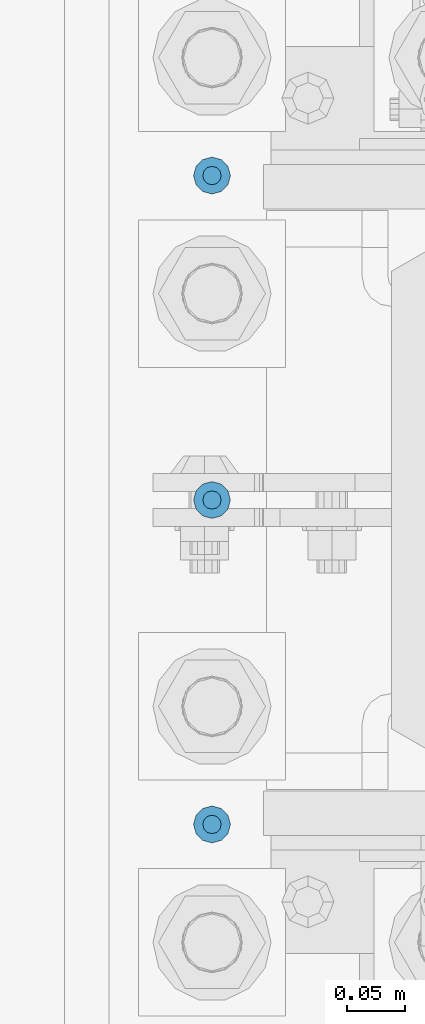
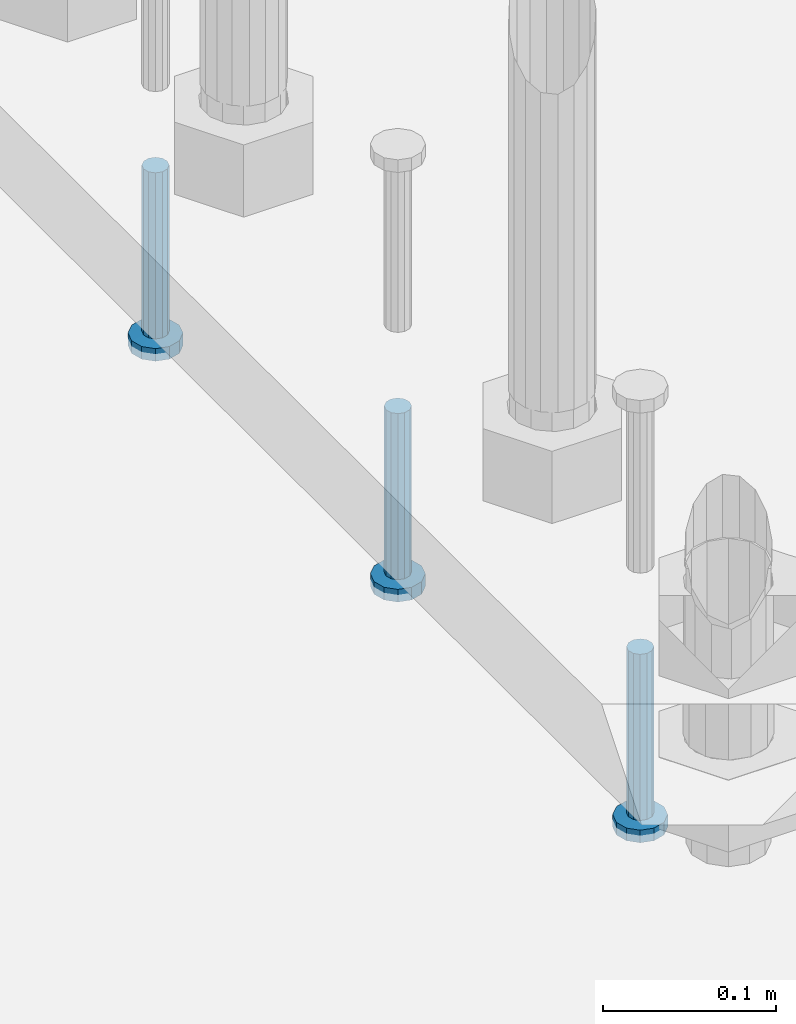
# One storey, part 1243 of 1876: 3 beams, 1 element without a shape of its own.
"""IFC2X3 building model written with IfcOpenShell, lengths in millimetres."""

from ifc_helpers import new_model, si_unit, frame, origin_with_axes, place, context, subcontext, project, spatial, faceted_brep, material, type_object, element, aggregate, save


model = new_model("IFC2X3")

# Units and contexts
model_context = context("Model", 3, precision=1e-05, world=origin_with_axes())
body_context = subcontext(model_context, "Body", "Model", "MODEL_VIEW")
ifc_project = project(units=[si_unit("LENGTHUNIT", "METRE", prefix="MILLI"), si_unit("AREAUNIT", "SQUARE_METRE"), si_unit("VOLUMEUNIT", "CUBIC_METRE"), si_unit("MASSUNIT", "GRAM", prefix="KILO"), si_unit("TIMEUNIT", "SECOND"), si_unit("PLANEANGLEUNIT", "RADIAN"), si_unit("SOLIDANGLEUNIT", "STERADIAN"), si_unit("THERMODYNAMICTEMPERATUREUNIT", "DEGREE_CELSIUS"), si_unit("LUMINOUSINTENSITYUNIT", "LUMEN")], contexts=[model_context])

# Site, building, storey
site_placement = place(None, origin_with_axes())
site = spatial("IfcSite", under=ifc_project, at=site_placement, CompositionType="ELEMENT")
building_placement = place(site_placement, origin_with_axes())
building = spatial("IfcBuilding", under=site, at=building_placement, Name="Undefined", CompositionType="ELEMENT")
storey_placement = place(building_placement, origin_with_axes())
storey = spatial("IfcBuildingStorey", under=building, at=storey_placement, Name="Undefined", CompositionType="ELEMENT", Elevation=0.0)

# Assembly, beams
assembly_placement = place(storey_placement, origin_with_axes())
assembly = element("IfcElementAssembly", 1, at=assembly_placement, inside=storey, Name="TEMPLATE", AssemblyPlace="NOTDEFINED", PredefinedType="RIGID_FRAME")
ifc_material = material(Name="STEEL/A108")
beam_type = type_object("IfcBeamType", Name="5/8-DIA_HEADED ANCHOR STUD", PredefinedType="NOTDEFINED")
beam_1_placement = place(assembly_placement, frame((7416.8, 1803.4, -793.75), z_axis=(1.0, 0.0, 0.0), x_axis=(0.0, 0.0, -1.0)))
beam_1 = element("IfcBeam", 2, at=beam_1_placement, type_object=beam_type, material=ifc_material, Name="HEADED ANCHOR STUD", ObjectType="5/8-DIA_HEADED ANCHOR STUD", context=body_context, shape_type="Brep", body=[
    faceted_brep([(0.0, -7.94000005722046, 0.0), (0.0, -6.86999988555908, -3.97000002861023), (116.84, -6.86999988555908, -3.97000002861023), (116.84, -7.94000005722046, 0.0), (0.0, -3.97000002861023, -6.86999988555908), (116.84, -3.97000002861023, -6.86999988555908), (0.0, 0.0, -7.94000005722046), (116.84, 0.0, -7.94000005722046), (0.0, 3.97000002861023, -6.86999988555908), (116.84, 3.97000002861023, -6.86999988555908), (0.0, 6.86999988555908, -3.97000002861023), (116.84, 6.86999988555908, -3.97000002861023), (0.0, 7.94000005722046, 0.0), (116.84, 7.94000005722046, 0.0), (0.0, 6.86999988555908, 3.97000002861023), (116.84, 6.86999988555908, 3.97000002861023), (0.0, 3.97000002861023, 6.86999988555908), (116.84, 3.97000002861023, 6.86999988555908), (0.0, 0.0, 7.94000005722046), (116.84, 0.0, 7.94000005722046), (0.0, -3.97000002861023, 6.86999988555908), (116.84, -3.97000002861023, 6.86999988555908), (0.0, -6.86999988555908, 3.97000002861023), (116.84, -6.86999988555908, 3.97000002861023), (118.11, -13.75, -7.94000005722046), (118.11, -15.8800001144409, 0.0), (118.11, -7.94000005722046, -13.75), (118.11, 0.0, -15.8800001144409), (118.11, 7.94000005722046, -13.75), (118.11, 13.75, -7.94000005722046), (118.11, 15.8800001144409, 0.0), (118.11, 13.75, 7.94000005722046), (118.11, 7.94000005722046, 13.75), (118.11, 0.0, 15.8800001144409), (118.11, -7.94000005722046, 13.75), (118.11, -13.75, 7.94000005722046), (127.0, -13.75, -7.94000005722046), (127.0, -15.8800001144409, 0.0), (127.0, -7.94000005722046, -13.75), (127.0, 0.0, -15.8800001144409), (127.0, 7.94000005722046, -13.75), (127.0, 13.75, -7.94000005722046), (127.0, 15.8800001144409, 0.0), (127.0, 13.75, 7.94000005722046), (127.0, 7.94000005722046, 13.75), (127.0, 0.0, 15.8800001144409), (127.0, -7.94000005722046, 13.75), (127.0, -13.75, 7.94000005722046)], [[[0, 1, 2, 3]], [[1, 4, 5, 2]], [[4, 6, 7, 5]], [[6, 8, 9, 7]], [[8, 10, 11, 9]], [[10, 12, 13, 11]], [[12, 14, 15, 13]], [[14, 16, 17, 15]], [[16, 18, 19, 17]], [[18, 20, 21, 19]], [[20, 22, 23, 21]], [[22, 0, 3, 23]], [[22, 20, 18, 16, 14, 12, 10, 8, 6, 4, 1, 0]], [[3, 2, 24, 25]], [[2, 5, 26, 24]], [[5, 7, 27, 26]], [[7, 9, 28, 27]], [[9, 11, 29, 28]], [[11, 13, 30, 29]], [[13, 15, 31, 30]], [[15, 17, 32, 31]], [[17, 19, 33, 32]], [[19, 21, 34, 33]], [[21, 23, 35, 34]], [[23, 3, 25, 35]], [[25, 24, 36, 37]], [[24, 26, 38, 36]], [[26, 27, 39, 38]], [[27, 28, 40, 39]], [[28, 29, 41, 40]], [[29, 30, 42, 41]], [[30, 31, 43, 42]], [[31, 32, 44, 43]], [[32, 33, 45, 44]], [[33, 34, 46, 45]], [[34, 35, 47, 46]], [[35, 25, 37, 47]], [[38, 39, 40, 41, 42, 43, 44, 45, 46, 47, 37, 36]]]),
])
beam_2_placement = place(assembly_placement, frame((7416.8, 1244.6, -793.75), z_axis=(1.0, 0.0, 0.0), x_axis=(0.0, 0.0, -1.0)))
beam_2 = element("IfcBeam", 3, at=beam_2_placement, type_object=beam_type, material=ifc_material, Name="HEADED ANCHOR STUD", ObjectType="5/8-DIA_HEADED ANCHOR STUD", context=body_context, shape_type="Brep", body=[
    faceted_brep([(0.0, -7.94000005722046, 0.0), (0.0, -6.86999988555908, -3.97000002861023), (116.84, -6.86999988555908, -3.97000002861023), (116.84, -7.94000005722046, 0.0), (0.0, -3.97000002861023, -6.86999988555908), (116.84, -3.97000002861023, -6.86999988555908), (0.0, 0.0, -7.94000005722046), (116.84, 0.0, -7.94000005722046), (0.0, 3.97000002861023, -6.86999988555908), (116.84, 3.97000002861023, -6.86999988555908), (0.0, 6.86999988555908, -3.97000002861023), (116.84, 6.86999988555908, -3.97000002861023), (0.0, 7.94000005722046, 0.0), (116.84, 7.94000005722046, 0.0), (0.0, 6.86999988555908, 3.97000002861023), (116.84, 6.86999988555908, 3.97000002861023), (0.0, 3.97000002861023, 6.86999988555908), (116.84, 3.97000002861023, 6.86999988555908), (0.0, 0.0, 7.94000005722046), (116.84, 0.0, 7.94000005722046), (0.0, -3.97000002861023, 6.86999988555908), (116.84, -3.97000002861023, 6.86999988555908), (0.0, -6.86999988555908, 3.97000002861023), (116.84, -6.86999988555908, 3.97000002861023), (118.11, -13.75, -7.94000005722046), (118.11, -15.8800001144409, 0.0), (118.11, -7.94000005722046, -13.75), (118.11, 0.0, -15.8800001144409), (118.11, 7.94000005722046, -13.75), (118.11, 13.75, -7.94000005722046), (118.11, 15.8800001144409, 0.0), (118.11, 13.75, 7.94000005722046), (118.11, 7.94000005722046, 13.75), (118.11, 0.0, 15.8800001144409), (118.11, -7.94000005722046, 13.75), (118.11, -13.75, 7.94000005722046), (127.0, -13.75, -7.94000005722046), (127.0, -15.8800001144409, 0.0), (127.0, -7.94000005722046, -13.75), (127.0, 0.0, -15.8800001144409), (127.0, 7.94000005722046, -13.75), (127.0, 13.75, -7.94000005722046), (127.0, 15.8800001144409, 0.0), (127.0, 13.75, 7.94000005722046), (127.0, 7.94000005722046, 13.75), (127.0, 0.0, 15.8800001144409), (127.0, -7.94000005722046, 13.75), (127.0, -13.75, 7.94000005722046)], [[[0, 1, 2, 3]], [[1, 4, 5, 2]], [[4, 6, 7, 5]], [[6, 8, 9, 7]], [[8, 10, 11, 9]], [[10, 12, 13, 11]], [[12, 14, 15, 13]], [[14, 16, 17, 15]], [[16, 18, 19, 17]], [[18, 20, 21, 19]], [[20, 22, 23, 21]], [[22, 0, 3, 23]], [[22, 20, 18, 16, 14, 12, 10, 8, 6, 4, 1, 0]], [[3, 2, 24, 25]], [[2, 5, 26, 24]], [[5, 7, 27, 26]], [[7, 9, 28, 27]], [[9, 11, 29, 28]], [[11, 13, 30, 29]], [[13, 15, 31, 30]], [[15, 17, 32, 31]], [[17, 19, 33, 32]], [[19, 21, 34, 33]], [[21, 23, 35, 34]], [[23, 3, 25, 35]], [[25, 24, 36, 37]], [[24, 26, 38, 36]], [[26, 27, 39, 38]], [[27, 28, 40, 39]], [[28, 29, 41, 40]], [[29, 30, 42, 41]], [[30, 31, 43, 42]], [[31, 32, 44, 43]], [[32, 33, 45, 44]], [[33, 34, 46, 45]], [[34, 35, 47, 46]], [[35, 25, 37, 47]], [[38, 39, 40, 41, 42, 43, 44, 45, 46, 47, 37, 36]]]),
])
beam_3_placement = place(assembly_placement, frame((7416.8, 1524.0, -793.75), z_axis=(1.0, 0.0, 0.0), x_axis=(0.0, 0.0, -1.0)))
beam_3 = element("IfcBeam", 4, at=beam_3_placement, type_object=beam_type, material=ifc_material, Name="HEADED ANCHOR STUD", ObjectType="5/8-DIA_HEADED ANCHOR STUD", context=body_context, shape_type="Brep", body=[
    faceted_brep([(0.0, -7.94000005722046, 0.0), (0.0, -6.86999988555908, -3.97000002861023), (116.84, -6.86999988555908, -3.97000002861023), (116.84, -7.94000005722046, 0.0), (0.0, -3.97000002861023, -6.86999988555908), (116.84, -3.97000002861023, -6.86999988555908), (0.0, 0.0, -7.94000005722046), (116.84, 0.0, -7.94000005722046), (0.0, 3.97000002861023, -6.86999988555908), (116.84, 3.97000002861023, -6.86999988555908), (0.0, 6.86999988555908, -3.97000002861023), (116.84, 6.86999988555908, -3.97000002861023), (0.0, 7.94000005722046, 0.0), (116.84, 7.94000005722046, 0.0), (0.0, 6.86999988555908, 3.97000002861023), (116.84, 6.86999988555908, 3.97000002861023), (0.0, 3.97000002861023, 6.86999988555908), (116.84, 3.97000002861023, 6.86999988555908), (0.0, 0.0, 7.94000005722046), (116.84, 0.0, 7.94000005722046), (0.0, -3.97000002861023, 6.86999988555908), (116.84, -3.97000002861023, 6.86999988555908), (0.0, -6.86999988555908, 3.97000002861023), (116.84, -6.86999988555908, 3.97000002861023), (118.11, -13.75, -7.94000005722046), (118.11, -15.8800001144409, 0.0), (118.11, -7.94000005722046, -13.75), (118.11, 0.0, -15.8800001144409), (118.11, 7.94000005722046, -13.75), (118.11, 13.75, -7.94000005722046), (118.11, 15.8800001144409, 0.0), (118.11, 13.75, 7.94000005722046), (118.11, 7.94000005722046, 13.75), (118.11, 0.0, 15.8800001144409), (118.11, -7.94000005722046, 13.75), (118.11, -13.75, 7.94000005722046), (127.0, -13.75, -7.94000005722046), (127.0, -15.8800001144409, 0.0), (127.0, -7.94000005722046, -13.75), (127.0, 0.0, -15.8800001144409), (127.0, 7.94000005722046, -13.75), (127.0, 13.75, -7.94000005722046), (127.0, 15.8800001144409, 0.0), (127.0, 13.75, 7.94000005722046), (127.0, 7.94000005722046, 13.75), (127.0, 0.0, 15.8800001144409), (127.0, -7.94000005722046, 13.75), (127.0, -13.75, 7.94000005722046)], [[[0, 1, 2, 3]], [[1, 4, 5, 2]], [[4, 6, 7, 5]], [[6, 8, 9, 7]], [[8, 10, 11, 9]], [[10, 12, 13, 11]], [[12, 14, 15, 13]], [[14, 16, 17, 15]], [[16, 18, 19, 17]], [[18, 20, 21, 19]], [[20, 22, 23, 21]], [[22, 0, 3, 23]], [[22, 20, 18, 16, 14, 12, 10, 8, 6, 4, 1, 0]], [[3, 2, 24, 25]], [[2, 5, 26, 24]], [[5, 7, 27, 26]], [[7, 9, 28, 27]], [[9, 11, 29, 28]], [[11, 13, 30, 29]], [[13, 15, 31, 30]], [[15, 17, 32, 31]], [[17, 19, 33, 32]], [[19, 21, 34, 33]], [[21, 23, 35, 34]], [[23, 3, 25, 35]], [[25, 24, 36, 37]], [[24, 26, 38, 36]], [[26, 27, 39, 38]], [[27, 28, 40, 39]], [[28, 29, 41, 40]], [[29, 30, 42, 41]], [[30, 31, 43, 42]], [[31, 32, 44, 43]], [[32, 33, 45, 44]], [[33, 34, 46, 45]], [[34, 35, 47, 46]], [[35, 25, 37, 47]], [[38, 39, 40, 41, 42, 43, 44, 45, 46, 47, 37, 36]]]),
])
aggregate(assembly, [beam_1, beam_2, beam_3])

save(model, "model.ifc")
